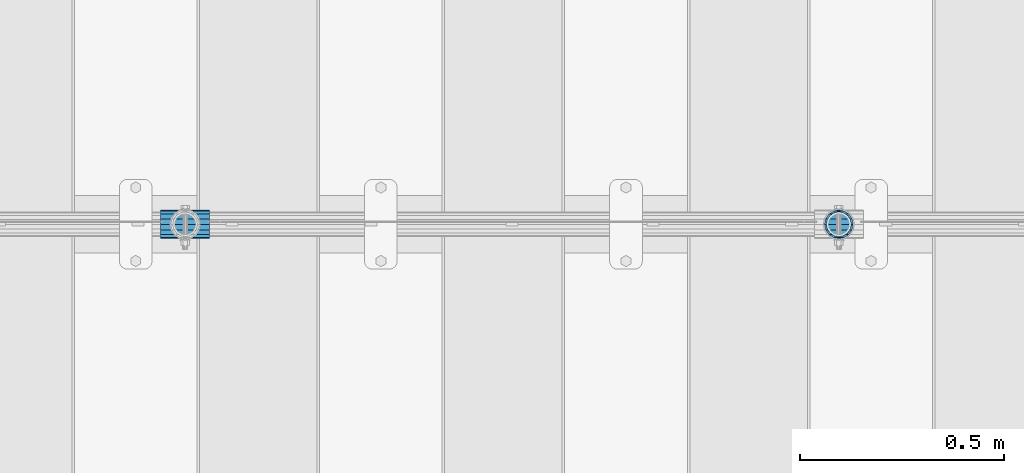
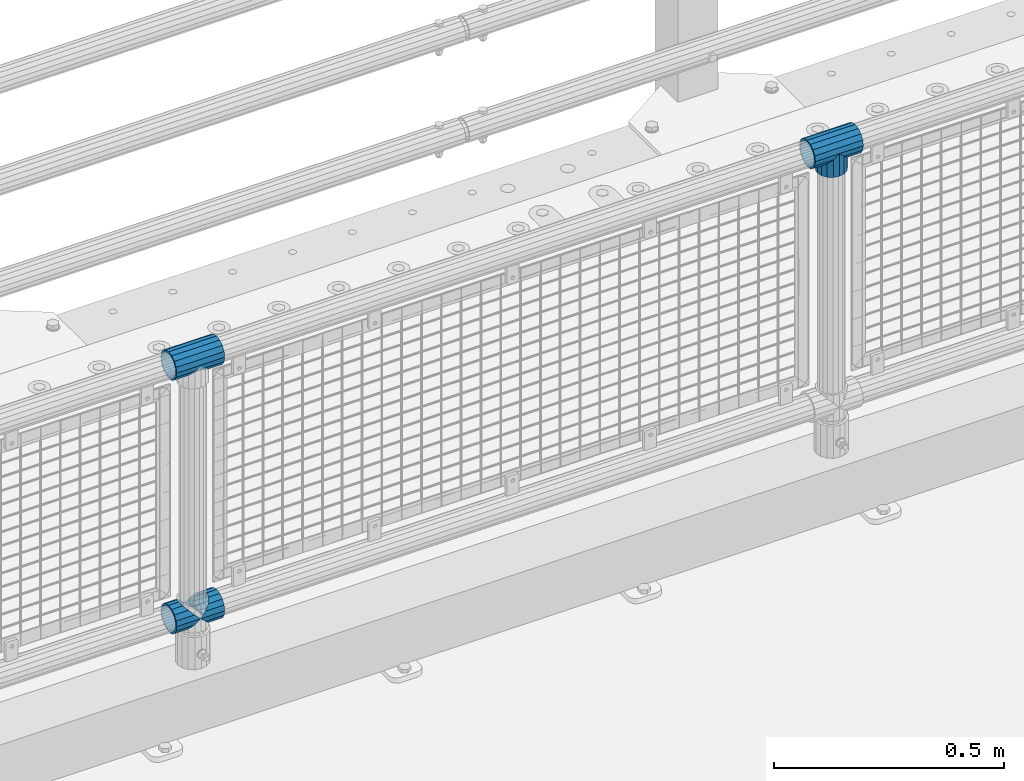
# One storey, part 150 of 247: 5 beams.
"""IFC2X3 building model written with IfcOpenShell, lengths in millimetres."""

from ifc_helpers import new_model, si_unit, frame, origin_with_axes, place, context, subcontext, project, spatial, faceted_brep, material, type_object, element, save


model = new_model("IFC2X3")

# Units and contexts
model_context = context("Model", 3, precision=1e-05, world=origin_with_axes())
body_context = subcontext(model_context, "Body", "Model", "MODEL_VIEW")
ifc_project = project(units=[si_unit("LENGTHUNIT", "METRE", prefix="MILLI"), si_unit("AREAUNIT", "SQUARE_METRE"), si_unit("VOLUMEUNIT", "CUBIC_METRE"), si_unit("MASSUNIT", "GRAM", prefix="KILO"), si_unit("TIMEUNIT", "SECOND"), si_unit("PLANEANGLEUNIT", "RADIAN"), si_unit("SOLIDANGLEUNIT", "STERADIAN"), si_unit("THERMODYNAMICTEMPERATUREUNIT", "DEGREE_CELSIUS"), si_unit("LUMINOUSINTENSITYUNIT", "LUMEN")], contexts=[model_context])

# Site, building, storey
site_placement = place(None, origin_with_axes())
site = spatial("IfcSite", under=ifc_project, at=site_placement, CompositionType="ELEMENT")
building_placement = place(site_placement, origin_with_axes())
building = spatial("IfcBuilding", under=site, at=building_placement, Name="Standard", CompositionType="ELEMENT")
storey_placement = place(building_placement, origin_with_axes())
storey = spatial("IfcBuildingStorey", under=building, at=storey_placement, Name="Undefined", CompositionType="ELEMENT", Elevation=0.0)

# Beams
ifc_material = material(Name="Misc_Undefined")
beam_type = type_object("IfcBeamType", PredefinedType="NOTDEFINED")
beam_1_placement = place(storey_placement, frame((5421.0, 7664.5, 969.849999999999), z_axis=(0.0, 1.0, 0.0), x_axis=(0.0, 0.0, -1.0)))
element("IfcBeam", 1, at=beam_1_placement, inside=storey, type_object=beam_type, material=ifc_material, context=body_context, shape_type="Brep", body=[
    faceted_brep([(0.0, 0.0, 35.1499999999996), (13.4513226476338, 13.4513226476329, 32.4743655677721), (13.4513226476338, -13.4513226476329, 32.4743655677721), (24.8548033587067, -16.3810424080045, -24.8548033587067), (24.8548033587067, -24.8548033587072, -24.8548033587067), (32.4743655677721, -32.4743655677717, -13.4513226476329), (32.4743655677721, -26.8123795176766, -13.4513226476329), (27.1226768591059, -21.4606908090117, -21.4606908090118), (0.0, 0.0, -35.1499999999996), (13.4513226476338, -13.4513226476329, -32.4743655677721), (13.4513226476338, 13.4513226476329, -32.4743655677721), (20.0882031229885, -11.6144421722805, -28.0397438117179), (16.6306603983739, 0.0, -30.3500000000004), (20.0882031229885, 11.6144421722805, -28.0397438117179), (24.8548033587067, 16.3810424080029, -24.8548033587067), (24.8548033587067, 24.8548033587072, -24.8548033587067), (27.1226768591059, 21.4606908090117, -21.4606908090118), (32.4743655677721, 26.8123795176755, -13.4513226476329), (32.4743655677721, 32.4743655677717, -13.4513226476329), (32.8397438117172, 28.0397438117175, -11.6144421722802), (35.1499999999996, 30.35, 0.0), (35.1499999999996, 35.15, 0.0), (32.8397438117172, 28.0397438117175, 11.6144421722802), (32.4743655677721, 26.8123795176755, 13.4513226476329), (32.4743655677721, 32.4743655677717, 13.4513226476329), (27.1226768591096, 21.4606908090117, 21.4606908090118), (24.8548033587067, 16.3810424080046, 24.8548033587067), (24.8548033587067, 24.8548033587072, 24.8548033587067), (20.0882031229812, 11.6144421722805, 28.0397438117179), (16.6306603983649, 0.0, 30.3500000000004), (20.0882031229812, -11.6144421722805, 28.0397438117179), (24.8548033587067, -16.3810424080045, 24.8548033587067), (24.8548033587067, -24.8548033587072, 24.8548033587067), (27.1226768591096, -21.4606908090117, 21.4606908090118), (32.4743655677721, -26.8123795176755, 13.4513226476329), (32.4743655677721, -32.4743655677717, 13.4513226476329), (32.8397438117172, -28.0397438117175, 11.6144421722802), (35.1499999999996, -30.35, 0.0), (35.1499999999996, -35.15, 0.0), (32.8397438117172, -28.0397438117175, -11.6144421722802), (60.1499999999996, -24.8548033587072, -24.8548033587067), (60.1499999999996, -32.4743655677717, -13.4513226476329), (60.1499999999996, -13.4513226476329, -32.4743655677721), (60.1499999999996, 0.0, -35.1499999999996), (60.1499999999996, 13.4513226476329, -32.4743655677721), (60.1499999999996, 24.8548033587072, -24.8548033587067), (60.1499999999996, 32.4743655677717, -13.4513226476329), (60.1499999999996, 35.15, 0.0), (60.1499999999996, 32.4743655677717, 13.4513226476329), (60.1499999999996, 24.8548033587072, 24.8548033587067), (60.1499999999996, 13.4513226476329, 32.4743655677721), (60.1499999999996, 0.0, 35.1499999999996), (60.1499999999996, -13.4513226476329, 32.4743655677721), (60.1499999999996, -24.8548033587072, 24.8548033587067), (60.1499999999996, -32.4743655677717, 13.4513226476329), (60.1499999999996, -35.15, 0.0), (60.1499999999996, -21.4606908090117, 21.4606908090118), (60.1499999999996, -11.6144421722805, 28.0397438117179), (60.1499999999996, 0.0, 30.3500000000004), (60.1499999999996, 11.6144421722805, 28.0397438117179), (60.1499999999996, 21.4606908090117, 21.4606908090118), (60.1499999999996, 28.0397438117175, 11.6144421722802), (60.1499999999996, 30.35, 0.0), (60.1499999999996, 28.0397438117175, -11.6144421722802), (60.1499999999996, 21.4606908090117, -21.4606908090118), (60.1499999999996, 11.6144421722805, -28.0397438117179), (60.1499999999996, 0.0, -30.3500000000004), (60.1499999999996, -11.6144421722805, -28.0397438117179), (60.1499999999996, -21.4606908090117, -21.4606908090118), (60.1499999999996, -28.0397438117175, -11.6144421722802), (60.1499999999996, -30.35, 0.0), (60.1499999999996, -28.0397438117175, 11.6144421722802)], [[[0, 1, 2]], [[3, 4, 5, 6, 7]], [[8, 9, 10]], [[10, 9, 4, 3, 11, 12, 13, 14, 15]], [[15, 14, 16, 17, 18]], [[18, 17, 19, 20, 21]], [[21, 20, 22, 23, 24]], [[24, 23, 25, 26, 27]], [[27, 26, 28, 29, 30, 31, 32, 2, 1]], [[33, 34, 35, 32, 31]], [[36, 37, 38, 35, 34]], [[6, 5, 38, 37, 39]], [[40, 41, 5, 4]], [[42, 40, 4, 9]], [[43, 42, 9, 8]], [[44, 43, 8, 10]], [[45, 44, 10, 15]], [[46, 45, 15, 18]], [[47, 46, 18, 21]], [[48, 47, 21, 24]], [[49, 48, 24, 27]], [[50, 49, 27, 1]], [[51, 50, 1, 0]], [[52, 51, 0, 2]], [[53, 52, 2, 32]], [[54, 53, 32, 35]], [[55, 54, 35, 38]], [[41, 55, 38, 5]], [[40, 42, 43, 44, 45, 46, 47, 48, 49, 50, 51, 52, 53, 54, 55, 41], [56, 57, 58, 59, 60, 61, 62, 63, 64, 65, 66, 67, 68, 69, 70, 71]], [[71, 70, 37, 36]], [[56, 71, 36, 34, 33]], [[57, 56, 33, 31, 30]], [[58, 57, 30, 29]], [[59, 58, 29, 28]], [[25, 60, 59, 28, 26]], [[22, 61, 60, 25, 23]], [[62, 61, 22, 20]], [[63, 62, 20, 19]], [[64, 63, 19, 17, 16]], [[65, 64, 16, 14, 13]], [[66, 65, 13, 12]], [[67, 66, 12, 11]], [[7, 68, 67, 11, 3]], [[39, 69, 68, 7, 6]], [[70, 69, 39, 37]]]),
])
beam_2_placement = place(storey_placement, frame((5360.85, 7664.5, 969.849999999999), z_axis=(0.0, 0.0, 1.0), x_axis=(1.0, 0.0, 0.0)))
element("IfcBeam", 2, at=beam_2_placement, inside=storey, type_object=beam_type, material=ifc_material, context=body_context, shape_type="Brep", body=[
    faceted_brep([(88.1897438117176, -11.6144421722802, -28.0397438117176), (88.1897438117176, -11.6144421722802, -32.8397438117175), (86.9623795176758, -13.4513226476329, -32.4743655677718), (81.6106908090114, -21.4606908090118, -27.1226768591068), (81.6106908090114, -21.4606908090118, -21.4606908090117), (76.5310424080035, -24.8548033587067, -24.8548033587072), (71.7644421722798, -28.0397438117179, -20.0882031229845), (71.7644421722798, -28.0397438117179, -11.6144421722805), (60.1499999999996, -30.3500000000004, -16.6306603983671), (60.1499999999996, -30.35, 0.0), (48.5355578277195, -28.0397438117179, -20.0882031229845), (48.5355578277195, -28.0397438117179, -11.6144421722805), (43.7689575919958, -24.8548033587067, -24.8548033587072), (38.6893091909878, -21.4606908090118, -27.1226768591068), (38.6893091909878, -21.4606908090118, -21.4606908090117), (33.3376204823217, -13.4513226476329, -32.4743655677718), (32.1102561882817, -11.6144421722802, -32.8397438117175), (32.1102561882817, -11.6144421722802, -28.0397438117176), (29.7999999999993, 0.0, -35.15), (29.7999999999993, 0.0, -30.35), (32.1102561882817, 11.6144421722802, -32.8397438117174), (32.1102561882817, 11.6144421722802, -28.0397438117176), (33.3376204823235, 13.4513226476329, -32.4743655677718), (38.6893091909878, 21.4606908090118, -27.122676859108), (38.6893091909878, 21.4606908090118, -21.4606908090117), (43.7689575919976, 24.8548033587067, -24.8548033587072), (48.5355578277195, 28.0397438117179, -20.0882031229829), (48.5355578277195, 28.0397438117179, -11.6144421722805), (60.1499999999996, 30.3500000000004, -16.6306603983655), (60.1499999999996, 30.35, 0.0), (71.7644421722798, 28.0397438117179, -20.0882031229829), (71.7644421722798, 28.0397438117179, -11.6144421722805), (76.5310424080035, 24.8548033587067, -24.8548033587072), (81.6106908090114, 21.4606908090118, -27.122676859108), (81.6106908090114, 21.4606908090118, -21.4606908090117), (86.9623795176758, 13.4513226476329, -32.4743655677718), (88.1897438117176, 11.6144421722802, -32.8397438117174), (88.1897438117176, 11.6144421722802, -28.0397438117176), (90.5, 0.0, -35.15), (90.5, 0.0, -30.35), (0.0, -21.4606908090118, -21.4606908090118), (0.0, -28.0397438117179, -11.6144421722802), (0.0, -11.6144421722802, -28.0397438117179), (0.0, 0.0, -30.3500000000004), (0.0, 11.6144421722802, -28.0397438117179), (0.0, 21.4606908090118, -21.4606908090118), (0.0, 28.0397438117179, -11.6144421722802), (0.0, 30.3500000000004, 0.0), (0.0, 32.4743655677721, -13.4513226476338), (0.0, 35.1499999999996, 0.0), (120.299999999999, 35.1499999999996, 0.0), (120.299999999999, 32.4743655677721, -13.4513226476329), (0.0, 32.4743655677721, 13.4513226476338), (120.299999999999, 32.4743655677721, 13.4513226476329), (0.0, 24.8548033587067, 24.8548033587067), (120.299999999999, 24.8548033587067, 24.8548033587072), (0.0, 13.4513226476329, 32.4743655677721), (120.299999999999, 13.4513226476329, 32.4743655677718), (0.0, 0.0, 35.1499999999996), (120.299999999999, 0.0, 35.15), (0.0, -13.4513226476329, 32.4743655677721), (120.299999999999, -13.4513226476329, 32.4743655677718), (0.0, -24.8548033587067, 24.8548033587067), (120.299999999999, -24.8548033587067, 24.8548033587072), (0.0, -32.4743655677721, 13.4513226476338), (120.299999999999, -32.4743655677721, 13.4513226476329), (0.0, -35.1499999999996, 0.0), (120.299999999999, -35.1499999999996, 0.0), (0.0, -32.4743655677721, -13.4513226476338), (120.299999999999, -32.4743655677721, -13.4513226476329), (0.0, 24.8548033587067, -24.8548033587067), (0.0, 13.4513226476329, -32.4743655677721), (0.0, 0.0, -35.1499999999996), (0.0, -13.4513226476329, -32.4743655677721), (0.0, -24.8548033587067, -24.8548033587067), (0.0, 28.0397438117179, 11.6144421722802), (0.0, 21.4606908090118, 21.4606908090118), (0.0, 11.6144421722802, 28.0397438117179), (0.0, 0.0, 30.3500000000004), (0.0, -11.6144421722802, 28.0397438117179), (0.0, -21.4606908090118, 21.4606908090118), (0.0, -28.0397438117179, 11.6144421722802), (0.0, -30.3500000000004, 0.0), (120.299999999999, -30.3500000000004, 0.0), (120.299999999999, -28.0397438117179, -11.6144421722805), (120.299999999999, -21.4606908090118, -21.4606908090117), (120.299999999999, -11.6144421722802, -28.0397438117176), (120.299999999999, 0.0, -30.35), (120.299999999999, 21.4606908090118, -21.4606908090117), (120.299999999999, 28.0397438117179, -11.6144421722805), (120.299999999999, 11.6144421722802, -28.0397438117176), (120.299999999999, 30.3500000000004, 0.0), (120.299999999999, 28.0397438117179, 11.6144421722805), (120.299999999999, 21.4606908090118, 21.4606908090117), (120.299999999999, 11.6144421722802, 28.0397438117176), (120.299999999999, 0.0, 30.35), (120.299999999999, -11.6144421722802, 28.0397438117176), (120.299999999999, -21.4606908090118, 21.4606908090117), (120.299999999999, -28.0397438117179, 11.6144421722805), (120.299999999999, -24.8548033587067, -24.8548033587072), (120.299999999999, -13.4513226476329, -32.4743655677718), (120.299999999999, 0.0, -35.15), (120.299999999999, 13.4513226476329, -32.4743655677718), (120.299999999999, 24.8548033587067, -24.8548033587072)], [[[0, 1, 2, 3, 4]], [[4, 3, 5, 6, 7]], [[7, 6, 8, 9]], [[9, 8, 10, 11]], [[11, 10, 12, 13, 14]], [[14, 13, 15, 16, 17]], [[17, 16, 18, 19]], [[19, 18, 20, 21]], [[21, 20, 22, 23, 24]], [[24, 23, 25, 26, 27]], [[27, 26, 28, 29]], [[29, 28, 30, 31]], [[31, 30, 32, 33, 34]], [[34, 33, 35, 36, 37]], [[37, 36, 38, 39]], [[39, 38, 1, 0]], [[40, 41, 11, 14]], [[42, 40, 14, 17]], [[43, 42, 17, 19]], [[44, 43, 19, 21]], [[45, 44, 21, 24]], [[46, 45, 24, 27]], [[47, 46, 27, 29]], [[48, 49, 50, 51]], [[49, 52, 53, 50]], [[52, 54, 55, 53]], [[54, 56, 57, 55]], [[56, 58, 59, 57]], [[58, 60, 61, 59]], [[60, 62, 63, 61]], [[62, 64, 65, 63]], [[64, 66, 67, 65]], [[66, 68, 69, 67]], [[64, 62, 60, 58, 56, 54, 52, 49, 48, 70, 71, 72, 73, 74, 68, 66], [41, 40, 42, 43, 44, 45, 46, 47, 75, 76, 77, 78, 79, 80, 81, 82]], [[41, 82, 9, 11]], [[83, 84, 7, 9]], [[84, 85, 4, 7]], [[85, 86, 0, 4]], [[86, 87, 39, 0]], [[88, 89, 31, 34]], [[90, 88, 34, 37]], [[87, 90, 37, 39]], [[89, 91, 29, 31]], [[75, 47, 29, 91, 92]], [[76, 75, 92, 93]], [[77, 76, 93, 94]], [[78, 77, 94, 95]], [[79, 78, 95, 96]], [[80, 79, 96, 97]], [[81, 80, 97, 98]], [[9, 82, 81, 98, 83]], [[99, 100, 101, 102, 103, 51, 50, 53, 55, 57, 59, 61, 63, 65, 67, 69], [97, 96, 95, 94, 93, 92, 91, 89, 88, 90, 87, 86, 85, 84, 83, 98]], [[35, 102, 101, 38, 36]], [[32, 103, 102, 35, 33]], [[28, 26, 25, 70, 48, 51, 103, 32, 30]], [[22, 71, 70, 25, 23]], [[18, 72, 71, 22, 20]], [[73, 72, 18, 16, 15]], [[74, 73, 15, 13, 12]], [[99, 69, 68, 74, 12, 10, 8, 6, 5]], [[100, 99, 5, 3, 2]], [[101, 100, 2, 1, 38]]]),
])
beam_3_placement = place(storey_placement, frame((3760.85, 7664.5, 969.849999999999), z_axis=(0.0, 0.0, 1.0), x_axis=(1.0, 0.0, 0.0)))
element("IfcBeam", 3, at=beam_3_placement, inside=storey, type_object=beam_type, material=ifc_material, context=body_context, shape_type="Brep", body=[
    faceted_brep([(88.1897438117176, -11.6144421722802, -28.0397438117176), (88.1897438117176, -11.6144421722802, -32.8397438117175), (86.9623795176758, -13.4513226476329, -32.4743655677718), (81.6106908090114, -21.4606908090118, -27.1226768591068), (81.6106908090114, -21.4606908090118, -21.4606908090117), (76.5310424080035, -24.8548033587067, -24.8548033587072), (71.7644421722798, -28.0397438117179, -20.0882031229845), (71.7644421722798, -28.0397438117179, -11.6144421722805), (60.1499999999996, -30.3500000000004, -16.6306603983671), (60.1499999999996, -30.35, 0.0), (48.5355578277195, -28.0397438117179, -20.0882031229845), (48.5355578277195, -28.0397438117179, -11.6144421722805), (43.7689575919958, -24.8548033587067, -24.8548033587072), (38.6893091909878, -21.4606908090118, -27.1226768591068), (38.6893091909878, -21.4606908090118, -21.4606908090117), (33.3376204823217, -13.4513226476329, -32.4743655677718), (32.1102561882817, -11.6144421722802, -32.8397438117175), (32.1102561882817, -11.6144421722802, -28.0397438117176), (29.7999999999993, 0.0, -35.15), (29.7999999999993, 0.0, -30.35), (32.1102561882817, 11.6144421722802, -32.8397438117174), (32.1102561882817, 11.6144421722802, -28.0397438117176), (33.3376204823235, 13.4513226476329, -32.4743655677718), (38.6893091909878, 21.4606908090118, -27.122676859108), (38.6893091909878, 21.4606908090118, -21.4606908090117), (43.7689575919976, 24.8548033587067, -24.8548033587072), (48.5355578277195, 28.0397438117179, -20.0882031229829), (48.5355578277195, 28.0397438117179, -11.6144421722805), (60.1499999999996, 30.3500000000004, -16.6306603983655), (60.1499999999996, 30.35, 0.0), (71.7644421722798, 28.0397438117179, -20.0882031229829), (71.7644421722798, 28.0397438117179, -11.6144421722805), (76.5310424080035, 24.8548033587067, -24.8548033587072), (81.6106908090114, 21.4606908090118, -27.122676859108), (81.6106908090114, 21.4606908090118, -21.4606908090117), (86.9623795176758, 13.4513226476329, -32.4743655677718), (88.1897438117176, 11.6144421722802, -32.8397438117174), (88.1897438117176, 11.6144421722802, -28.0397438117176), (90.5, 0.0, -35.15), (90.5, 0.0, -30.35), (0.0, -21.4606908090118, -21.4606908090118), (0.0, -28.0397438117179, -11.6144421722802), (0.0, -11.6144421722802, -28.0397438117179), (0.0, 0.0, -30.3500000000004), (0.0, 11.6144421722802, -28.0397438117179), (0.0, 21.4606908090118, -21.4606908090118), (0.0, 28.0397438117179, -11.6144421722802), (0.0, 30.3500000000004, 0.0), (0.0, 32.4743655677721, -13.4513226476338), (0.0, 35.1499999999996, 0.0), (120.299999999999, 35.1499999999996, 0.0), (120.299999999999, 32.4743655677721, -13.4513226476329), (0.0, 32.4743655677721, 13.4513226476338), (120.299999999999, 32.4743655677721, 13.4513226476329), (0.0, 24.8548033587067, 24.8548033587067), (120.299999999999, 24.8548033587067, 24.8548033587072), (0.0, 13.4513226476329, 32.4743655677721), (120.299999999999, 13.4513226476329, 32.4743655677718), (0.0, 0.0, 35.1499999999996), (120.299999999999, 0.0, 35.15), (0.0, -13.4513226476329, 32.4743655677721), (120.299999999999, -13.4513226476329, 32.4743655677718), (0.0, -24.8548033587067, 24.8548033587067), (120.299999999999, -24.8548033587067, 24.8548033587072), (0.0, -32.4743655677721, 13.4513226476338), (120.299999999999, -32.4743655677721, 13.4513226476329), (0.0, -35.1499999999996, 0.0), (120.299999999999, -35.1499999999996, 0.0), (0.0, -32.4743655677721, -13.4513226476338), (120.299999999999, -32.4743655677721, -13.4513226476329), (0.0, 24.8548033587067, -24.8548033587067), (0.0, 13.4513226476329, -32.4743655677721), (0.0, 0.0, -35.1499999999996), (0.0, -13.4513226476329, -32.4743655677721), (0.0, -24.8548033587067, -24.8548033587067), (0.0, 28.0397438117179, 11.6144421722802), (0.0, 21.4606908090118, 21.4606908090118), (0.0, 11.6144421722802, 28.0397438117179), (0.0, 0.0, 30.3500000000004), (0.0, -11.6144421722802, 28.0397438117179), (0.0, -21.4606908090118, 21.4606908090118), (0.0, -28.0397438117179, 11.6144421722802), (0.0, -30.3500000000004, 0.0), (120.299999999999, -30.3500000000004, 0.0), (120.299999999999, -28.0397438117179, -11.6144421722805), (120.299999999999, -21.4606908090118, -21.4606908090117), (120.299999999999, -11.6144421722802, -28.0397438117176), (120.299999999999, 0.0, -30.35), (120.299999999999, 21.4606908090118, -21.4606908090117), (120.299999999999, 28.0397438117179, -11.6144421722805), (120.299999999999, 11.6144421722802, -28.0397438117176), (120.299999999999, 30.3500000000004, 0.0), (120.299999999999, 28.0397438117179, 11.6144421722805), (120.299999999999, 21.4606908090118, 21.4606908090117), (120.299999999999, 11.6144421722802, 28.0397438117176), (120.299999999999, 0.0, 30.35), (120.299999999999, -11.6144421722802, 28.0397438117176), (120.299999999999, -21.4606908090118, 21.4606908090117), (120.299999999999, -28.0397438117179, 11.6144421722805), (120.299999999999, -24.8548033587067, -24.8548033587072), (120.299999999999, -13.4513226476329, -32.4743655677718), (120.299999999999, 0.0, -35.15), (120.299999999999, 13.4513226476329, -32.4743655677718), (120.299999999999, 24.8548033587067, -24.8548033587072)], [[[0, 1, 2, 3, 4]], [[4, 3, 5, 6, 7]], [[7, 6, 8, 9]], [[9, 8, 10, 11]], [[11, 10, 12, 13, 14]], [[14, 13, 15, 16, 17]], [[17, 16, 18, 19]], [[19, 18, 20, 21]], [[21, 20, 22, 23, 24]], [[24, 23, 25, 26, 27]], [[27, 26, 28, 29]], [[29, 28, 30, 31]], [[31, 30, 32, 33, 34]], [[34, 33, 35, 36, 37]], [[37, 36, 38, 39]], [[39, 38, 1, 0]], [[40, 41, 11, 14]], [[42, 40, 14, 17]], [[43, 42, 17, 19]], [[44, 43, 19, 21]], [[45, 44, 21, 24]], [[46, 45, 24, 27]], [[47, 46, 27, 29]], [[48, 49, 50, 51]], [[49, 52, 53, 50]], [[52, 54, 55, 53]], [[54, 56, 57, 55]], [[56, 58, 59, 57]], [[58, 60, 61, 59]], [[60, 62, 63, 61]], [[62, 64, 65, 63]], [[64, 66, 67, 65]], [[66, 68, 69, 67]], [[64, 62, 60, 58, 56, 54, 52, 49, 48, 70, 71, 72, 73, 74, 68, 66], [41, 40, 42, 43, 44, 45, 46, 47, 75, 76, 77, 78, 79, 80, 81, 82]], [[41, 82, 9, 11]], [[83, 84, 7, 9]], [[84, 85, 4, 7]], [[85, 86, 0, 4]], [[86, 87, 39, 0]], [[88, 89, 31, 34]], [[90, 88, 34, 37]], [[87, 90, 37, 39]], [[89, 91, 29, 31]], [[75, 47, 29, 91, 92]], [[76, 75, 92, 93]], [[77, 76, 93, 94]], [[78, 77, 94, 95]], [[79, 78, 95, 96]], [[80, 79, 96, 97]], [[81, 80, 97, 98]], [[9, 82, 81, 98, 83]], [[99, 100, 101, 102, 103, 51, 50, 53, 55, 57, 59, 61, 63, 65, 67, 69], [97, 96, 95, 94, 93, 92, 91, 89, 88, 90, 87, 86, 85, 84, 83, 98]], [[35, 102, 101, 38, 36]], [[32, 103, 102, 35, 33]], [[28, 26, 25, 70, 48, 51, 103, 32, 30]], [[22, 71, 70, 25, 23]], [[18, 72, 71, 22, 20]], [[73, 72, 18, 16, 15]], [[74, 73, 15, 13, 12]], [[99, 69, 68, 74, 12, 10, 8, 6, 5]], [[100, 99, 5, 3, 2]], [[101, 100, 2, 1, 38]]]),
])
beam_4_placement = place(storey_placement, frame((3760.85, 7664.5, 298.17), z_axis=(0.0, 1.0, 0.0), x_axis=(1.0, 0.0, 0.0)))
element("IfcBeam", 4, at=beam_4_placement, inside=storey, type_object=beam_type, material=ifc_material, context=body_context, shape_type="Brep", body=[
    faceted_brep([(60.1499999999996, 0.0, -35.1499999999996), (46.6986773523668, 13.4513226476329, -32.4743655677721), (46.6986773523668, -13.4513226476329, -32.4743655677721), (33.0273231408919, 21.4606908090117, 21.4606908090118), (27.675634432228, 26.8123795176755, 13.4513226476329), (27.675634432228, 32.4743655677717, 13.4513226476329), (35.2951966412925, 24.8548033587072, 24.8548033587067), (35.2951966412925, 16.3810424080048, 24.8548033587067), (27.3102561882824, 28.0397438117175, 11.6144421722802), (24.9999999999995, 30.35, 0.0), (24.9999999999995, 35.15, 0.0), (27.675634432228, 26.8123795176764, -13.4513226476329), (27.675634432228, 32.4743655677717, -13.4513226476329), (27.310256188282, 28.0397438117175, -11.6144421722802), (35.2951966412925, 16.3810424080032, -24.8548033587067), (35.2951966412925, 24.8548033587072, -24.8548033587067), (33.0273231408928, 21.4606908090117, -21.4606908090118), (40.0617968770157, 11.6144421722805, -28.0397438117179), (43.5193396016348, 0.0, -30.3500000000004), (40.0617968770157, -11.6144421722805, -28.0397438117179), (35.2951966412925, -16.3810424080032, -24.8548033587067), (35.2951966412925, -24.8548033587072, -24.8548033587067), (33.0273231408928, -21.4606908090117, -21.4606908090118), (27.675634432228, -26.8123795176766, -13.4513226476329), (27.675634432228, -32.4743655677717, -13.4513226476329), (27.310256188282, -28.0397438117175, -11.6144421722802), (24.9999999999995, -30.35, 0.0), (24.9999999999995, -35.15, 0.0), (27.3102561882824, -28.0397438117175, 11.6144421722802), (27.675634432228, -26.8123795176764, 13.4513226476329), (27.675634432228, -32.4743655677717, 13.4513226476329), (33.0273231408919, -21.4606908090117, 21.4606908090118), (35.2951966412925, -16.3810424080032, 24.8548033587067), (35.2951966412925, -24.8548033587072, 24.8548033587067), (60.1499999999996, 0.0, 35.1499999999996), (46.6986773523668, -13.4513226476329, 32.4743655677721), (46.6986773523668, 13.4513226476329, 32.4743655677721), (40.0617968770157, -11.6144421722805, 28.0397438117179), (43.519339601633, 0.0, 30.3500000000004), (40.0617968770157, 11.6144421722805, 28.0397438117179), (0.0, -32.4743655677721, -13.4513226476338), (0.0, -24.8548033587067, -24.8548033587067), (0.0, -13.4513226476329, -32.4743655677721), (0.0, 0.0, -35.1499999999996), (0.0, 13.4513226476329, -32.4743655677721), (0.0, 24.8548033587067, -24.8548033587067), (0.0, 32.4743655677721, -13.4513226476338), (0.0, 35.1499999999996, 0.0), (0.0, 32.4743655677721, 13.4513226476338), (0.0, 24.8548033587067, 24.8548033587067), (0.0, 13.4513226476329, 32.4743655677721), (0.0, 0.0, 35.1499999999996), (0.0, -32.4743655677721, 13.4513226476338), (0.0, -35.1499999999996, 0.0), (0.0, -24.8548033587067, 24.8548033587067), (0.0, -13.4513226476329, 32.4743655677721), (0.0, -28.0397438117179, -11.6144421722802), (0.0, -21.4606908090118, -21.4606908090118), (0.0, -11.6144421722802, -28.0397438117179), (0.0, 0.0, -30.3500000000004), (0.0, 11.6144421722802, -28.0397438117179), (0.0, 21.4606908090118, -21.4606908090118), (0.0, 28.0397438117179, -11.6144421722802), (0.0, 30.3500000000004, 0.0), (0.0, 28.0397438117179, 11.6144421722802), (0.0, 21.4606908090118, 21.4606908090118), (0.0, 11.6144421722802, 28.0397438117179), (0.0, 0.0, 30.3500000000004), (0.0, -11.6144421722802, 28.0397438117179), (0.0, -21.4606908090118, 21.4606908090118), (0.0, -28.0397438117179, 11.6144421722802), (0.0, -30.3500000000004, 0.0)], [[[0, 1, 2]], [[3, 4, 5, 6, 7]], [[8, 9, 10, 5, 4]], [[11, 12, 10, 9, 13]], [[14, 15, 12, 11, 16]], [[2, 1, 15, 14, 17, 18, 19, 20, 21]], [[21, 20, 22, 23, 24]], [[24, 23, 25, 26, 27]], [[27, 26, 28, 29, 30]], [[30, 29, 31, 32, 33]], [[34, 35, 36]], [[33, 32, 37, 38, 39, 7, 6, 36, 35]], [[40, 41, 21, 24]], [[41, 42, 2, 21]], [[42, 43, 0, 2]], [[43, 44, 1, 0]], [[44, 45, 15, 1]], [[45, 46, 12, 15]], [[46, 47, 10, 12]], [[47, 48, 5, 10]], [[48, 49, 6, 5]], [[49, 50, 36, 6]], [[50, 51, 34, 36]], [[52, 53, 27, 30]], [[54, 52, 30, 33]], [[55, 54, 33, 35]], [[51, 55, 35, 34]], [[53, 40, 24, 27]], [[52, 54, 55, 51, 50, 49, 48, 47, 46, 45, 44, 43, 42, 41, 40, 53], [56, 57, 58, 59, 60, 61, 62, 63, 64, 65, 66, 67, 68, 69, 70, 71]], [[68, 67, 38, 37]], [[31, 69, 68, 37, 32]], [[28, 70, 69, 31, 29]], [[71, 70, 28, 26]], [[56, 71, 26, 25]], [[57, 56, 25, 23, 22]], [[58, 57, 22, 20, 19]], [[59, 58, 19, 18]], [[60, 59, 18, 17]], [[16, 61, 60, 17, 14]], [[13, 62, 61, 16, 11]], [[63, 62, 13, 9]], [[64, 63, 9, 8]], [[65, 64, 8, 4, 3]], [[66, 65, 3, 7, 39]], [[67, 66, 39, 38]]]),
])
beam_5_placement = place(storey_placement, frame((3821.0, 7664.5, 298.17), z_axis=(0.0, 1.0, 0.0), x_axis=(1.0, 0.0, 0.0)))
element("IfcBeam", 5, at=beam_5_placement, inside=storey, type_object=beam_type, material=ifc_material, context=body_context, shape_type="Brep", body=[
    faceted_brep([(0.0, 0.0, 35.1499999999996), (13.4513226476338, 13.4513226476329, 32.4743655677721), (13.4513226476338, -13.4513226476329, 32.4743655677721), (24.8548033587067, -16.3810424080045, -24.8548033587067), (24.8548033587067, -24.8548033587072, -24.8548033587067), (32.4743655677721, -32.4743655677717, -13.4513226476329), (32.4743655677721, -26.8123795176766, -13.4513226476329), (27.1226768591059, -21.4606908090117, -21.4606908090118), (0.0, 0.0, -35.1499999999996), (13.4513226476338, -13.4513226476329, -32.4743655677721), (13.4513226476338, 13.4513226476329, -32.4743655677721), (20.0882031229885, -11.6144421722805, -28.0397438117179), (16.6306603983739, 0.0, -30.3500000000004), (20.0882031229885, 11.6144421722805, -28.0397438117179), (24.8548033587067, 16.3810424080029, -24.8548033587067), (24.8548033587067, 24.8548033587072, -24.8548033587067), (27.1226768591059, 21.4606908090117, -21.4606908090118), (32.4743655677721, 26.8123795176755, -13.4513226476329), (32.4743655677721, 32.4743655677717, -13.4513226476329), (32.8397438117172, 28.0397438117175, -11.6144421722802), (35.1499999999996, 30.35, 0.0), (35.1499999999996, 35.15, 0.0), (32.8397438117172, 28.0397438117175, 11.6144421722802), (32.4743655677721, 26.8123795176755, 13.4513226476329), (32.4743655677721, 32.4743655677717, 13.4513226476329), (27.1226768591096, 21.4606908090117, 21.4606908090118), (24.8548033587067, 16.3810424080046, 24.8548033587067), (24.8548033587067, 24.8548033587072, 24.8548033587067), (20.0882031229812, 11.6144421722805, 28.0397438117179), (16.6306603983649, 0.0, 30.3500000000004), (20.0882031229812, -11.6144421722805, 28.0397438117179), (24.8548033587067, -16.3810424080045, 24.8548033587067), (24.8548033587067, -24.8548033587072, 24.8548033587067), (27.1226768591096, -21.4606908090117, 21.4606908090118), (32.4743655677721, -26.8123795176755, 13.4513226476329), (32.4743655677721, -32.4743655677717, 13.4513226476329), (32.8397438117172, -28.0397438117175, 11.6144421722802), (35.1499999999996, -30.35, 0.0), (35.1499999999996, -35.15, 0.0), (32.8397438117172, -28.0397438117175, -11.6144421722802), (60.1499999999996, -24.8548033587072, -24.8548033587067), (60.1499999999996, -32.4743655677717, -13.4513226476329), (60.1499999999996, -13.4513226476329, -32.4743655677721), (60.1499999999996, 0.0, -35.1499999999996), (60.1499999999996, 13.4513226476329, -32.4743655677721), (60.1499999999996, 24.8548033587072, -24.8548033587067), (60.1499999999996, 32.4743655677717, -13.4513226476329), (60.1499999999996, 35.15, 0.0), (60.1499999999996, 32.4743655677717, 13.4513226476329), (60.1499999999996, 24.8548033587072, 24.8548033587067), (60.1499999999996, 13.4513226476329, 32.4743655677721), (60.1499999999996, 0.0, 35.1499999999996), (60.1499999999996, -13.4513226476329, 32.4743655677721), (60.1499999999996, -24.8548033587072, 24.8548033587067), (60.1499999999996, -32.4743655677717, 13.4513226476329), (60.1499999999996, -35.15, 0.0), (60.1499999999996, -21.4606908090117, 21.4606908090118), (60.1499999999996, -11.6144421722805, 28.0397438117179), (60.1499999999996, 0.0, 30.3500000000004), (60.1499999999996, 11.6144421722805, 28.0397438117179), (60.1499999999996, 21.4606908090117, 21.4606908090118), (60.1499999999996, 28.0397438117175, 11.6144421722802), (60.1499999999996, 30.35, 0.0), (60.1499999999996, 28.0397438117175, -11.6144421722802), (60.1499999999996, 21.4606908090117, -21.4606908090118), (60.1499999999996, 11.6144421722805, -28.0397438117179), (60.1499999999996, 0.0, -30.3500000000004), (60.1499999999996, -11.6144421722805, -28.0397438117179), (60.1499999999996, -21.4606908090117, -21.4606908090118), (60.1499999999996, -28.0397438117175, -11.6144421722802), (60.1499999999996, -30.35, 0.0), (60.1499999999996, -28.0397438117175, 11.6144421722802)], [[[0, 1, 2]], [[3, 4, 5, 6, 7]], [[8, 9, 10]], [[10, 9, 4, 3, 11, 12, 13, 14, 15]], [[15, 14, 16, 17, 18]], [[18, 17, 19, 20, 21]], [[21, 20, 22, 23, 24]], [[24, 23, 25, 26, 27]], [[27, 26, 28, 29, 30, 31, 32, 2, 1]], [[33, 34, 35, 32, 31]], [[36, 37, 38, 35, 34]], [[6, 5, 38, 37, 39]], [[40, 41, 5, 4]], [[42, 40, 4, 9]], [[43, 42, 9, 8]], [[44, 43, 8, 10]], [[45, 44, 10, 15]], [[46, 45, 15, 18]], [[47, 46, 18, 21]], [[48, 47, 21, 24]], [[49, 48, 24, 27]], [[50, 49, 27, 1]], [[51, 50, 1, 0]], [[52, 51, 0, 2]], [[53, 52, 2, 32]], [[54, 53, 32, 35]], [[55, 54, 35, 38]], [[41, 55, 38, 5]], [[40, 42, 43, 44, 45, 46, 47, 48, 49, 50, 51, 52, 53, 54, 55, 41], [56, 57, 58, 59, 60, 61, 62, 63, 64, 65, 66, 67, 68, 69, 70, 71]], [[71, 70, 37, 36]], [[56, 71, 36, 34, 33]], [[57, 56, 33, 31, 30]], [[58, 57, 30, 29]], [[59, 58, 29, 28]], [[25, 60, 59, 28, 26]], [[22, 61, 60, 25, 23]], [[62, 61, 22, 20]], [[63, 62, 20, 19]], [[64, 63, 19, 17, 16]], [[65, 64, 16, 14, 13]], [[66, 65, 13, 12]], [[67, 66, 12, 11]], [[7, 68, 67, 11, 3]], [[39, 69, 68, 7, 6]], [[70, 69, 39, 37]]]),
])

save(model, "model.ifc")
